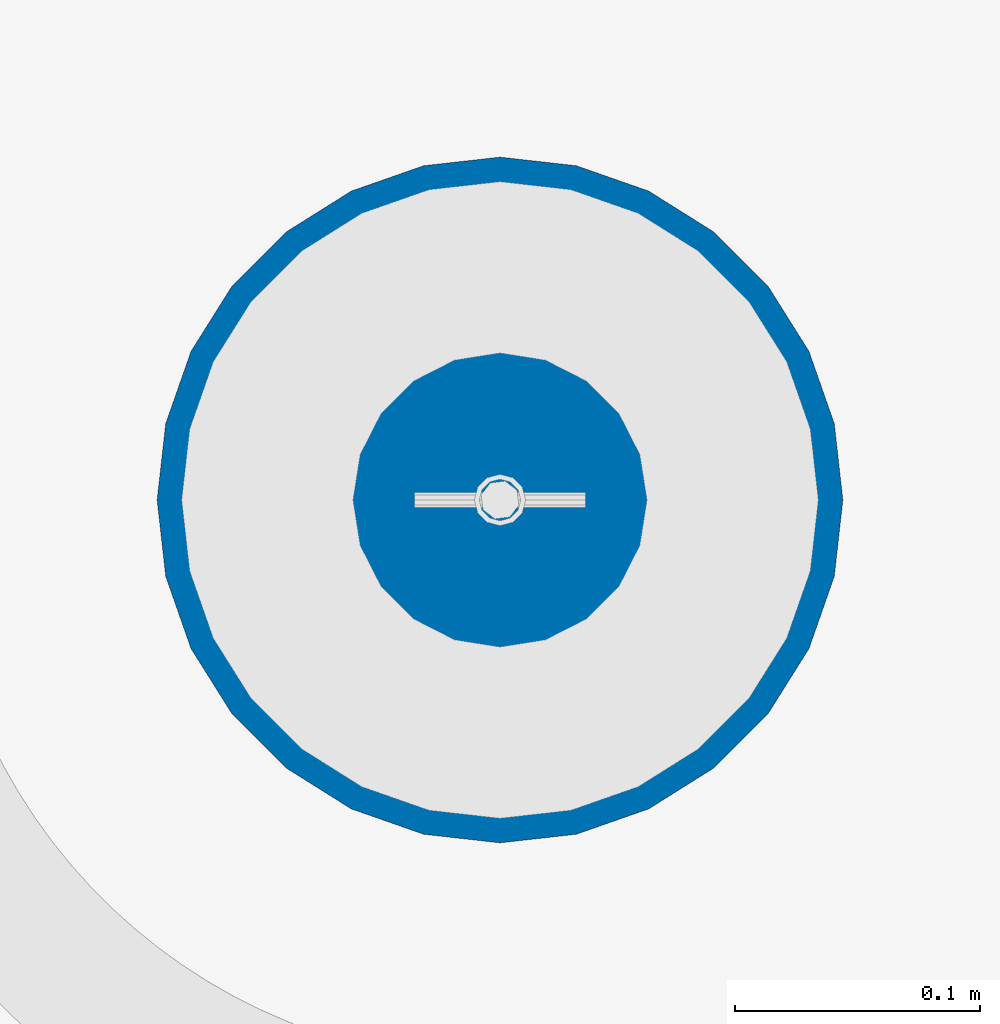
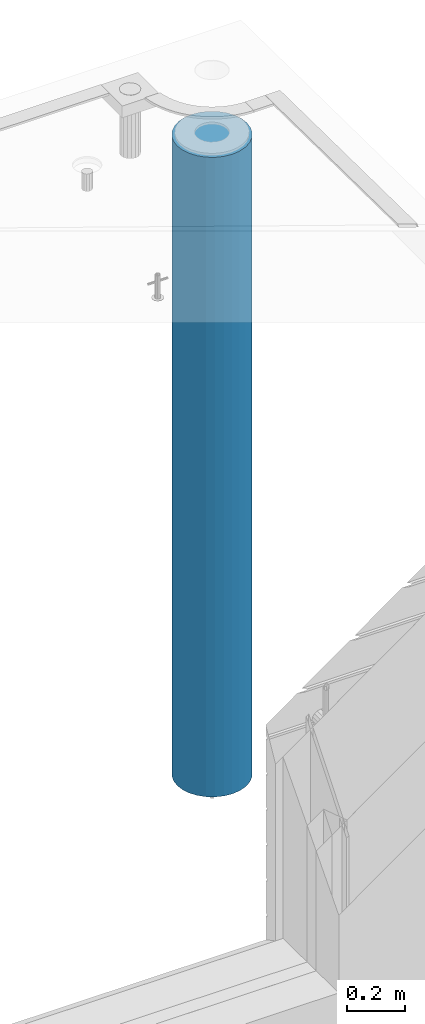
# One storey, part 6 of 325: 1 column, 1 element without a shape of its own.
"""IFC2X3 building model written with IfcOpenShell, lengths in millimetres."""

import ifcopenshell
import ifcopenshell.guid

model = None  # the IFC model being written
_history = None  # IfcOwnerHistory: only IFC2X3 demands one
_inside = {}  # id of a spatial element -> (the spatial element, [elements in it])
_under = {}  # id of a project, library or spatial element -> (it, [spatial elements below it])
_declared = {}  # id of a project -> (the project, [libraries it declares])
_typed = {}  # id of a type object -> (the type object, [elements of that type])
_made_of = {}  # id of a material, layer set ... -> (it, [elements and type objects made of it])


def new_model(schema):
    """Start an empty IFC model of exactly this schema.

    Asked for "IFC4X3", IfcOpenShell would pick the latest addendum, in which some entities
    have other attributes; the version numbers below select the first issue.
    IFC2X3 requires an IfcOwnerHistory on every rooted entity: one is made here for all.
    """
    global model, _history
    if schema == "IFC4X3":
        model = ifcopenshell.file(schema_version=(4, 3, 0, 0))
    else:
        model = ifcopenshell.file(schema=schema)
    _inside.clear()
    _under.clear()
    _declared.clear()
    _typed.clear()
    _made_of.clear()
    _history = None
    if model.schema == "IFC2X3":
        org = make("IfcOrganization", Name="unknown")
        user = make(
            "IfcPersonAndOrganization",
            ThePerson=make("IfcPerson", FamilyName="unknown"),
            TheOrganization=org,
        )
        app = make(
            "IfcApplication",
            ApplicationDeveloper=org,
            Version="unknown",
            ApplicationFullName="unknown",
            ApplicationIdentifier="unknown",
        )
        _history = make(
            "IfcOwnerHistory",
            OwningUser=user,
            OwningApplication=app,
            ChangeAction="ADDED",
            CreationDate=0,
        )
    return model


def make(cls, **values):
    """One entity of the class cls with the attributes given. An attribute that is None is left unset."""
    return model.create_entity(
        cls, **{name: value for name, value in values.items() if value is not None}
    )


def rooted(cls, **values):
    """An entity with a GlobalId (a new one), such as an element, a storey or a relation."""
    return make(cls, GlobalId=ifcopenshell.guid.new(), OwnerHistory=_history, **values)


def si_unit(unit_type, name, prefix=None):
    """IfcSIUnit, for example si_unit("LENGTHUNIT", "METRE", prefix="MILLI")."""
    return make("IfcSIUnit", UnitType=unit_type, Prefix=prefix, Name=name)


def assignment(units):
    """IfcUnitAssignment: the units of a project."""
    return None if units is None else make("IfcUnitAssignment", Units=units)


def point(xyz):
    """IfcCartesianPoint."""
    return None if xyz is None else make("IfcCartesianPoint", Coordinates=xyz)


def direction(xyz):
    """IfcDirection."""
    return None if xyz is None else make("IfcDirection", DirectionRatios=xyz)


def frame(location, z_axis=None, x_axis=None):
    """IfcAxis2Placement3D, a coordinate frame: its origin and axes. An axis left out is left unset."""
    return make(
        "IfcAxis2Placement3D",
        Location=point(location),
        Axis=direction(z_axis),
        RefDirection=direction(x_axis),
    )


def origin_with_axes():
    """The frame at (0, 0, 0) with the z axis (0, 0, 1) and the x axis (1, 0, 0) written out."""
    return frame((0.0, 0.0, 0.0), z_axis=(0.0, 0.0, 1.0), x_axis=(1.0, 0.0, 0.0))


def place(relative_to, where):
    """IfcLocalPlacement: puts the frame where relative to a parent placement (None: the world)."""
    return make(
        "IfcLocalPlacement", PlacementRelTo=relative_to, RelativePlacement=where
    )


def context(
    kind, dimensions, precision=None, world=None, true_north=None, identifier=None
):
    """IfcGeometricRepresentationContext, for example the 3D "Model" context."""
    return make(
        "IfcGeometricRepresentationContext",
        ContextIdentifier=identifier,
        ContextType=kind,
        CoordinateSpaceDimension=dimensions,
        Precision=precision,
        WorldCoordinateSystem=world,
        TrueNorth=true_north,
    )


def subcontext(parent, identifier, kind, view, scale=None):
    """IfcGeometricRepresentationSubContext, for example "Body" below "Model"."""
    return make(
        "IfcGeometricRepresentationSubContext",
        ContextIdentifier=identifier,
        ContextType=kind,
        ParentContext=parent,
        TargetScale=scale,
        TargetView=view,
    )


def project(units=None, contexts=None):
    """IfcProject with its units and contexts."""
    return rooted(
        "IfcProject",
        Name="project",
        RepresentationContexts=contexts,
        UnitsInContext=assignment(units),
    )


def spatial(cls, under=None, at=None, **own):
    """A site, building, storey or space (cls), placed at a placement, below another one or the project."""
    s = rooted(cls, ObjectPlacement=at, **own)
    if under is not None:
        _under.setdefault(under.id(), (under, []))[1].append(s)
    return s


def faces_of(points, faces, orient=None, outer=None):
    """IfcFace entities. A face is a list of loops; a loop is a list of indices into points, from 0.

    orient and outer hold one flag for each loop. By default every Orientation is true, the
    first loop of a face is its IfcFaceOuterBound and the others are IfcFaceBound.
    """
    made = []
    for i, loops in enumerate(faces):
        bounds = []
        for j, loop in enumerate(loops):
            is_outer = j == 0 if outer is None else outer[i][j]
            bounds.append(
                make(
                    "IfcFaceOuterBound" if is_outer else "IfcFaceBound",
                    Bound=make("IfcPolyLoop", Polygon=[points[k] for k in loop]),
                    Orientation=True if orient is None else orient[i][j],
                )
            )
        made.append(make("IfcFace", Bounds=bounds))
    return made


def faceted_brep(points, faces, orient=None, outer=None, voids=None):
    """IfcFacetedBrep: a solid bounded by flat faces; with voids (closed shells), ...WithVoids."""
    shared = [point(p) for p in points]
    hull = make("IfcClosedShell", CfsFaces=faces_of(shared, faces, orient, outer))
    if voids is None:
        return make("IfcFacetedBrep", Outer=hull)
    return make(
        "IfcFacetedBrepWithVoids",
        Outer=hull,
        Voids=[
            make(cls, CfsFaces=faces_of(shared, fs, o, b)) for cls, fs, o, b in voids
        ],
    )


def shape(context_of_items, identifier, shape_type, items):
    """IfcShapeRepresentation: the items that make up one representation, for example the "Body"."""
    return make(
        "IfcShapeRepresentation",
        ContextOfItems=context_of_items,
        RepresentationIdentifier=identifier,
        RepresentationType=shape_type,
        Items=items,
    )


def material(Name=None, Category=None):
    """IfcMaterial."""
    return make("IfcMaterial", Name=Name, Category=Category)


def made_of(thing, what):
    """Note that an element or type object is made of a material, layer set ...; save() writes the relation."""
    if what is not None:
        _made_of.setdefault(what.id(), (what, []))[1].append(thing)
    return thing


def type_object(cls, material=None, **own):
    """A type object (cls), such as IfcWallType, which elements share."""
    return made_of(rooted(cls, **own), material)


def element(
    cls,
    number,
    at=None,
    inside=None,
    cuts=None,
    type_object=None,
    material=None,
    context=None,
    identifier="Body",
    shape_type=None,
    held_by="IfcProductDefinitionShape",
    body=None,
    shapes=None,
    **own,
):
    """One element of the class cls, such as IfcWall. Its Tag is "e" and its number.

    at: its placement. inside: the storey or other place that contains it. cuts: it is an
    opening in that element (IfcRelVoidsElement). A single representation is given by context,
    identifier, shape_type and body (its items); several are given by shapes. held_by: the class
    of the entity that holds the representations. save() writes the other relations.
    """
    e = rooted(cls, Tag="e%d" % number, ObjectPlacement=at, **own)
    if body is not None:
        shapes = [shape(context, identifier, shape_type, body)]
    if shapes is not None:
        e.Representation = make(held_by, Representations=shapes)
    if inside is not None:
        _inside.setdefault(inside.id(), (inside, []))[1].append(e)
    if cuts is not None:
        rooted(
            "IfcRelVoidsElement", RelatingBuildingElement=cuts, RelatedOpeningElement=e
        )
    if type_object is not None:
        _typed.setdefault(type_object.id(), (type_object, []))[1].append(e)
    return made_of(e, material)


def aggregate(whole, parts):
    """IfcRelAggregates: a whole, such as a stair, and the parts it consists of."""
    return rooted("IfcRelAggregates", RelatingObject=whole, RelatedObjects=parts)


def save(model, path):
    """Write the relations noted so far, then the file.

    IfcRelAggregates (storeys below a building ...), IfcRelContainedInSpatialStructure (elements
    in a storey), IfcRelDefinesByType, IfcRelAssociatesMaterial and IfcRelDeclares: one each for
    every whole, place, type object, material and project.
    """
    for whole, parts in _under.values():
        aggregate(whole, parts)
    for where, things in _inside.values():
        rooted(
            "IfcRelContainedInSpatialStructure",
            RelatedElements=things,
            RelatingStructure=where,
        )
    for kind, things in _typed.values():
        rooted("IfcRelDefinesByType", RelatedObjects=things, RelatingType=kind)
    for what, things in _made_of.values():
        rooted("IfcRelAssociatesMaterial", RelatedObjects=things, RelatingMaterial=what)
    for by, libraries in _declared.values():
        rooted("IfcRelDeclares", RelatingContext=by, RelatedDefinitions=libraries)
    model.write(path)


model = new_model("IFC2X3")

# Units and contexts
model_context = context("Model", 3, precision=1e-05, world=origin_with_axes())
body_context = subcontext(model_context, "Body", "Model", "MODEL_VIEW")
ifc_project = project(units=[si_unit("LENGTHUNIT", "METRE", prefix="MILLI"), si_unit("AREAUNIT", "SQUARE_METRE"), si_unit("VOLUMEUNIT", "CUBIC_METRE"), si_unit("MASSUNIT", "GRAM", prefix="KILO"), si_unit("TIMEUNIT", "SECOND"), si_unit("PLANEANGLEUNIT", "RADIAN"), si_unit("SOLIDANGLEUNIT", "STERADIAN"), si_unit("THERMODYNAMICTEMPERATUREUNIT", "DEGREE_CELSIUS"), si_unit("LUMINOUSINTENSITYUNIT", "LUMEN")], contexts=[model_context])

# Site, building, storey
site_placement = place(None, origin_with_axes())
site = spatial("IfcSite", under=ifc_project, at=site_placement, CompositionType="ELEMENT")
building_placement = place(site_placement, origin_with_axes())
building = spatial("IfcBuilding", under=site, at=building_placement, CompositionType="ELEMENT")
storey_placement = place(building_placement, origin_with_axes())
storey = spatial("IfcBuildingStorey", under=building, at=storey_placement, Name="1", CompositionType="ELEMENT", Elevation=0.0)

# Assembly, column
assembly_placement = place(storey_placement, origin_with_axes())
assembly = element("IfcElementAssembly", 1, at=assembly_placement, inside=storey, AssemblyPlace="NOTDEFINED", PredefinedType="REINFORCEMENT_UNIT")
ifc_material = material(Name="CONCRETE/C30/37")
column_type = type_object("IfcColumnType", Name="D280", PredefinedType="NOTDEFINED")
column_placement = place(assembly_placement, frame((35009.9987952044, 22669.984888838, 81725.0), z_axis=(-1.0, 3.00000001838171e-08, 0.0), x_axis=(0.0, 0.0, 1.0)))
column = element("IfcColumn", 2, at=column_placement, type_object=column_type, material=ifc_material, ObjectType="D280", context=body_context, shape_type="Brep", body=[
    faceted_brep([(0.0, -140.0, 0.0), (0.0, -136.489907705454, -31.1529307538876), (2710.0, -136.489907705454, -31.1529307538876), (2710.0, -140.0, 0.0), (0.0, -126.135641506338, -60.7437234764584), (2710.0, -126.135641506338, -60.7437234764584), (0.0, -109.456407545524, -87.2885722602223), (2710.0, -109.456407545524, -87.2885722602223), (0.0, -87.2885722602223, -109.456407545527), (2710.0, -87.2885722602223, -109.456407545527), (0.0, -60.7437234764584, -126.135641506342), (2710.0, -60.7437234764584, -126.135641506342), (0.0, -31.152930753884, -136.489907705458), (2710.0, -31.152930753884, -136.489907705458), (0.0, 0.0, -140.0), (2710.0, 0.0, -140.0), (0.0, 31.152930753884, -136.489907705458), (2710.0, 31.152930753884, -136.489907705458), (0.0, 60.7437234764584, -126.135641506342), (2710.0, 60.7437234764584, -126.135641506342), (0.0, 87.2885722602223, -109.456407545527), (2710.0, 87.2885722602223, -109.456407545527), (0.0, 109.456407545524, -87.2885722602223), (2710.0, 109.456407545524, -87.2885722602223), (0.0, 126.135641506338, -60.7437234764584), (2710.0, 126.135641506338, -60.7437234764584), (0.0, 136.489907705454, -31.1529307538876), (2710.0, 136.489907705454, -31.1529307538876), (0.0, 140.0, 0.0), (2710.0, 140.0, 0.0), (0.0, 136.489907705454, 31.1529307538876), (2710.0, 136.489907705454, 31.1529307538876), (0.0, 126.135641506338, 60.7437234764584), (2710.0, 126.135641506338, 60.7437234764584), (0.0, 109.456407545524, 87.2885722602223), (2710.0, 109.456407545524, 87.2885722602223), (0.0, 87.2885722602223, 109.456407545527), (2710.0, 87.2885722602223, 109.456407545527), (0.0, 60.7437234764584, 126.135641506342), (2710.0, 60.7437234764584, 126.135641506342), (0.0, 31.152930753884, 136.489907705458), (2710.0, 31.152930753884, 136.489907705458), (0.0, 0.0, 140.0), (2710.0, 0.0, 140.0), (0.0, -31.152930753884, 136.489907705458), (2710.0, -31.152930753884, 136.489907705458), (0.0, -60.7437234764584, 126.135641506342), (2710.0, -60.7437234764584, 126.135641506342), (0.0, -87.2885722602223, 109.456407545527), (2710.0, -87.2885722602223, 109.456407545527), (0.0, -109.456407545524, 87.2885722602223), (2710.0, -109.456407545524, 87.2885722602223), (0.0, -126.135641506338, 60.7437234764584), (2710.0, -126.135641506338, 60.7437234764584), (0.0, -136.489907705454, 31.1529307538876), (2710.0, -136.489907705454, 31.1529307538876)], [[[0, 1, 2, 3]], [[1, 4, 5, 2]], [[4, 6, 7, 5]], [[6, 8, 9, 7]], [[8, 10, 11, 9]], [[10, 12, 13, 11]], [[12, 14, 15, 13]], [[14, 16, 17, 15]], [[16, 18, 19, 17]], [[18, 20, 21, 19]], [[20, 22, 23, 21]], [[22, 24, 25, 23]], [[24, 26, 27, 25]], [[26, 28, 29, 27]], [[28, 30, 31, 29]], [[30, 32, 33, 31]], [[32, 34, 35, 33]], [[34, 36, 37, 35]], [[36, 38, 39, 37]], [[38, 40, 41, 39]], [[40, 42, 43, 41]], [[42, 44, 45, 43]], [[44, 46, 47, 45]], [[46, 48, 49, 47]], [[48, 50, 51, 49]], [[50, 52, 53, 51]], [[52, 54, 55, 53]], [[54, 0, 3, 55]], [[5, 7, 9, 11, 13, 15, 17, 19, 21, 23, 25, 27, 29, 31, 33, 35, 37, 39, 41, 43, 45, 47, 49, 51, 53, 55, 3, 2]], [[54, 52, 50, 48, 46, 44, 42, 40, 38, 36, 34, 32, 30, 28, 26, 24, 22, 20, 18, 16, 14, 12, 10, 8, 6, 4, 1, 0]]]),
])
aggregate(assembly, [column])

save(model, "model.ifc")
